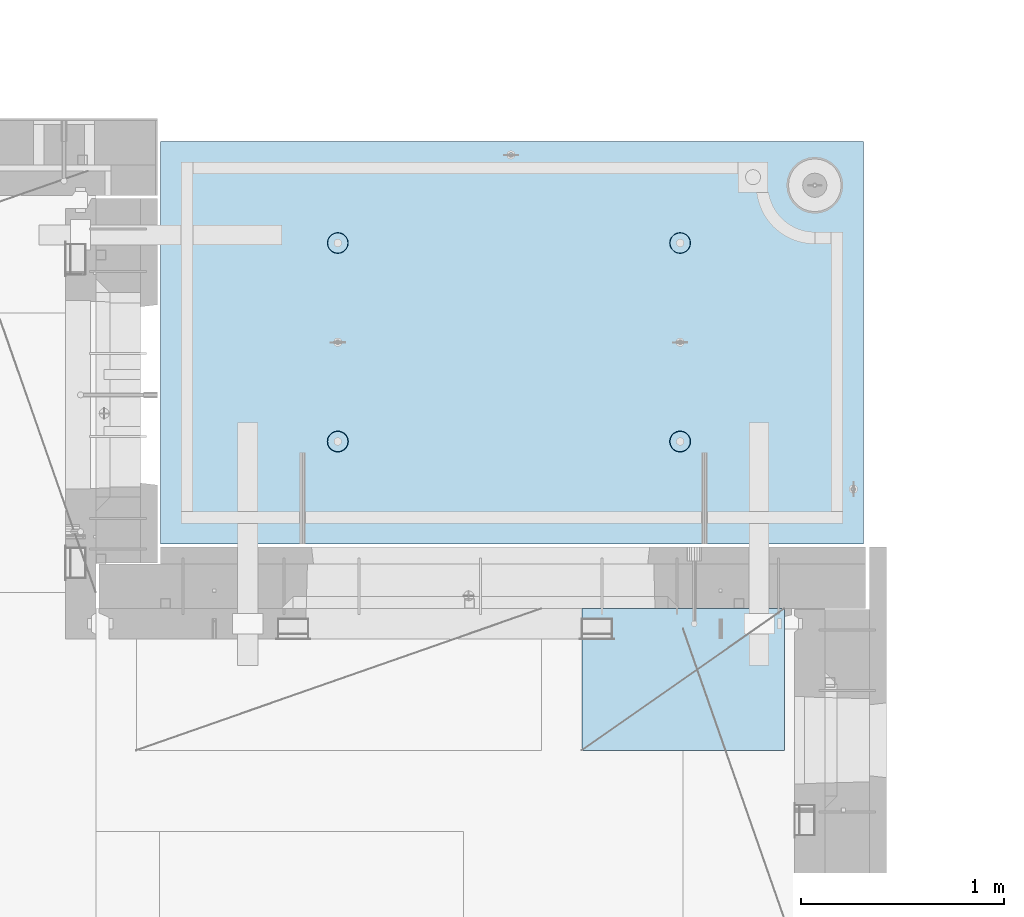
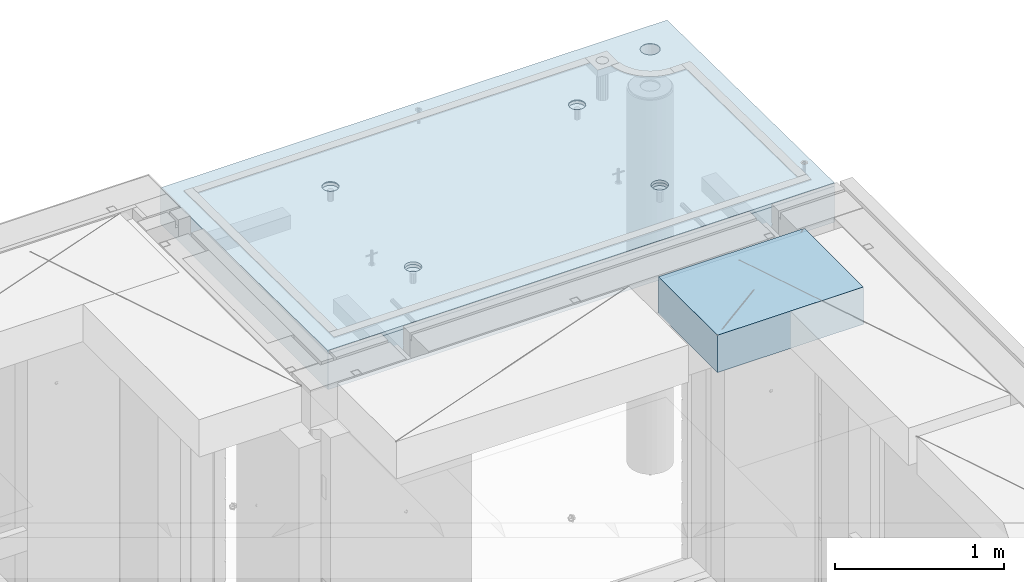
# One storey, part 191 of 325: 2 slabs, 1 plate, 2 elements without a shape of their own.
"""IFC2X3 building model written with IfcOpenShell, lengths in millimetres."""

from ifc_helpers import new_model, si_unit, frame, origin_with_axes, place, context, subcontext, project, spatial, faceted_brep, material, type_object, element, aggregate, save


model = new_model("IFC2X3")

# Units and contexts
model_context = context("Model", 3, precision=1e-05, world=origin_with_axes())
body_context = subcontext(model_context, "Body", "Model", "MODEL_VIEW")
ifc_project = project(units=[si_unit("LENGTHUNIT", "METRE", prefix="MILLI"), si_unit("AREAUNIT", "SQUARE_METRE"), si_unit("VOLUMEUNIT", "CUBIC_METRE"), si_unit("MASSUNIT", "GRAM", prefix="KILO"), si_unit("TIMEUNIT", "SECOND"), si_unit("PLANEANGLEUNIT", "RADIAN"), si_unit("SOLIDANGLEUNIT", "STERADIAN"), si_unit("THERMODYNAMICTEMPERATUREUNIT", "DEGREE_CELSIUS"), si_unit("LUMINOUSINTENSITYUNIT", "LUMEN")], contexts=[model_context])

# Site, building, storey
site_placement = place(None, origin_with_axes())
site = spatial("IfcSite", under=ifc_project, at=site_placement, CompositionType="ELEMENT")
building_placement = place(site_placement, origin_with_axes())
building = spatial("IfcBuilding", under=site, at=building_placement, CompositionType="ELEMENT")
storey_placement = place(building_placement, origin_with_axes())
storey = spatial("IfcBuildingStorey", under=building, at=storey_placement, Name="1", CompositionType="ELEMENT", Elevation=0.0)

# Assembly, slabs
assembly_1_placement = place(storey_placement, origin_with_axes())
assembly_1 = element("IfcElementAssembly", 1, at=assembly_1_placement, inside=storey, AssemblyPlace="NOTDEFINED", PredefinedType="REINFORCEMENT_UNIT")
ifc_material_1 = material(Name="CONCRETE/C35/45")
slab_type_1 = type_object("IfcSlabType", PredefinedType="NOTDEFINED")
slab_1_placement = place(assembly_1_placement, frame((31779.9998568133, 20899.9965573523, 84717.5), z_axis=(0.0, 1.0, 0.0), x_axis=(1.0, 0.0, 0.0)))
slab_1 = element("IfcSlab", 2, at=slab_1_placement, type_object=slab_type_1, material=ifc_material_1, PredefinedType="FLOOR", context=body_context, shape_type="Brep", body=[
    faceted_brep([(3287.06232936882, 9.55874156874779, 1751.46731182328), (3287.06232936882, 12.4999999999563, 1751.46731182328), (3278.5399580536, 12.4999999999563, 1734.74121634823), (3278.5399580536, 9.3480858430994, 1734.74121634823), (3265.26605352866, 12.4999999999563, 1721.46731182328), (3265.26605352866, 9.18090851265879, 1721.46731182328), (3248.5399580536, 12.4999999999563, 1712.94494050807), (3248.5399580536, 9.07357405936637, 1712.94494050807), (3229.99893839111, 12.4999999999563, 1710.00833148578), (3229.99893839111, 9.03658912732499, 1710.00833148578), (3211.45791872861, 12.4999999999563, 1712.94494050807), (3211.45791872861, 9.07357405936637, 1712.94494050807), (3194.73182325356, 12.4999999999563, 1721.46731182328), (3194.73182325356, 9.18090851267334, 1721.46731182328), (3181.45791872861, 12.4999999999563, 1734.74121634823), (3181.45791872861, 9.3480858430994, 1734.74121634823), (3172.9355474134, 12.4999999999563, 1751.46731182328), (3172.9355474134, 9.55874156874779, 1751.46731182328), (3169.99893839111, 12.4999999999563, 1770.00833148578), (3169.99893839111, 9.79225523948844, 1770.00833148578), (3172.9355474134, 12.4999999999563, 1788.54935114827), (3172.9355474134, 10.0257689102291, 1788.54935114827), (3181.45791872861, 12.4999999999563, 1805.27544662332), (3181.45791872861, 10.236424635892, 1805.27544662332), (3194.73182325356, 12.4999999999563, 1818.54935114827), (3194.73182325356, 10.4036019663181, 1818.54935114827), (3211.45791872861, 12.4999999999563, 1827.07172246349), (3211.45791872861, 10.5109364196105, 1827.07172246349), (3229.99893839111, 12.4999999999563, 1830.00833148578), (3229.99893839111, 10.5479213516664, 1830.00833148578), (3248.5399580536, 12.4999999999563, 1827.07172246349), (3248.5399580536, 10.5109364196105, 1827.07172246349), (3265.26605352866, 12.4999999999563, 1818.54935114827), (3265.26605352866, 10.4036019663181, 1818.54935114827), (3278.5399580536, 12.4999999999563, 1805.27544662332), (3278.5399580536, 10.2364246358775, 1805.27544662332), (3287.06232936882, 12.4999999999563, 1788.54935114827), (3287.06232936882, 10.0257689102291, 1788.54935114827), (3289.99893839111, 12.4999999999563, 1770.00833148578), (3289.99893839111, 9.79225523948844, 1770.00833148578), (7.41420080885291e-08, 12.4999999999927, 0.0), (-7.41420080885291e-08, -12.5, -3.63797880709171e-12), (0.0, 12.5, 1985.00366210938), (3470.0, 12.5, 0.0), (3470.00000000004, 12.4999999999563, 1985.00366210935), (3470.0, -12.5, 0.0), (2614.71871715545, -5.93617388149141, 521.168755308547), (2613.67503600632, 12.4999999999709, 520.829642746605), (2616.18047624359, 12.4999999999709, 505.010915653602), (2617.28998057371, -6.13967274603783, 505.010915653602), (2607.28293696061, -5.7526757610467, 535.738532951145), (2606.40396524136, 12.4999999999709, 535.099922616191), (2595.7125242481, -5.60710538028798, 547.296842506817), (2595.0790070157, 12.4999999999709, 546.424880841845), (2581.14006820649, -5.51366887726181, 554.715714533479), (2580.80872714612, 12.4999999999709, 553.695951606805), (2564.99000005311, -5.48147745869937, 557.271717883286), (2564.99000005311, 12.4999999999709, 556.201391844079), (2548.83993189974, -5.51366887726181, 554.715714533479), (2549.17127296011, 12.4999999999709, 553.695951606805), (2534.26747585813, -5.60710538028798, 547.296842506817), (2534.90099309052, 12.4999999999709, 546.424880841845), (2522.69706314561, -5.75267576103215, 535.738532951145), (2523.57603486487, 12.4999999999709, 535.099922616191), (2515.26128295077, -5.93617388147686, 521.168755308547), (2516.30496409991, 12.4999999999709, 520.829642746605), (2512.69001953251, -6.13967274603783, 505.010915653602), (2513.79952386263, 12.4999999999709, 505.010915653602), (2515.23823726424, -6.34326591769059, 488.84558800119), (2516.30496409991, 12.4999999999709, 489.192188560599), (2522.65977443627, -6.52701093736687, 474.256206522903), (2523.57603486487, 12.4999999999709, 474.921908691009), (2534.2301871423, -6.67288650246337, 462.673665286093), (2534.90099309052, 12.4999999999709, 463.596950465359), (2548.81688620273, -6.76656990486663, 455.235189411429), (2549.17127296011, 12.4999999999709, 456.325879700398), (2564.99000005311, -6.79885563062271, 452.67169805654), (2564.99000005311, 12.4999999999709, 453.820439463125), (2581.16311390349, -6.76656990486663, 455.235189411429), (2580.80872714612, 12.4999999999709, 456.325879700398), (2595.74981296392, -6.67288650246337, 462.673665286093), (2595.07900701571, 12.4999999999709, 463.596950465359), (2607.32022566996, -6.52701093736687, 474.256206522903), (2606.40396524136, 12.4999999999709, 474.921908691009), (2614.74176284199, -6.34326591769059, 488.84558800119), (2613.67503600632, 12.4999999999709, 489.192188560599), (924.718717121814, -5.93617388307757, 521.168755181017), (923.675035972585, 12.4999999999854, 520.829642619046), (926.180476209858, 12.4999999999854, 505.010915526043), (927.289980540074, -6.13967274762399, 505.010915526043), (917.282936926953, -5.75267576263286, 535.738532823641), (916.403965207624, 12.4999999999854, 535.099922488633), (905.712524214421, -5.60710538187413, 547.296842379335), (905.07900698197, 12.4999999999854, 546.424880714287), (891.140068172776, -5.51366887886252, 554.715714406011), (890.808727112384, 12.4999999999854, 553.695951479247), (874.990000019381, -5.48147746030008, 557.271717755822), (874.990000019381, 12.4999999999854, 556.20139171652), (858.839931865987, -5.51366887886252, 554.715714406011), (859.171272926378, 12.4999999999854, 553.695951479247), (844.267475824341, -5.60710538187413, 547.296842379335), (844.900993056792, 12.4999999999854, 546.424880714287), (832.697063111809, -5.75267576263286, 535.738532823641), (833.576034831138, 12.4999999999854, 535.099922488633), (825.261282916948, -5.93617388307757, 521.168755181017), (826.304964066177, 12.4999999999854, 520.829642619046), (822.690019498688, -6.13967274762399, 505.010915526043), (823.799523828904, 12.4999999999854, 505.010915526043), (825.238237230413, -6.34326591927675, 488.845587873602), (826.304964066174, 12.4999999999854, 489.19218843304), (832.659774402466, -6.52701093895303, 474.25620639529), (833.576034831141, 12.4999999999854, 474.921908563454), (844.230187108518, -6.67288650404953, 462.673665158458), (844.900993056788, 12.4999999999854, 463.5969503378), (858.816886168974, -6.76656990646734, 455.23518928378), (859.171272926378, 12.4999999999854, 456.32587957284), (874.990000019381, -6.79885563222342, 452.671697928887), (874.990000019381, 12.4999999999854, 453.820439335566), (891.163113869789, -6.76656990646734, 455.23518928378), (890.808727112384, 12.4999999999854, 456.32587957284), (905.749812930244, -6.67288650404953, 462.673665158458), (905.079006981974, 12.4999999999854, 463.5969503378), (917.320225636297, -6.52701093895303, 474.25620639529), (916.403965207621, 12.4999999999854, 474.921908563454), (924.741762808349, -6.34326591927675, 488.845587873602), (923.675035972588, 12.4999999999854, 489.19218843304), (924.02016693788, 6.4034111394576, 1500.93361352766), (923.67503595199, 12.4999999999854, 1500.82147367257), (926.18047618926, 12.4999999999854, 1485.00274657956), (926.555311256641, 6.20277086795249, 1485.00274657956), (916.688838773403, 6.58433162167785, 1515.29872631776), (916.403965187026, 12.4999999999854, 1515.09175354215), (905.280958178348, 6.7278571434581, 1526.69467377167), (905.079006961372, 12.4999999999854, 1526.4167117678), (890.913204613287, 6.81998112349538, 1534.0093312807), (890.808727091786, 12.4999999999854, 1533.68778253277), (874.989999998783, 6.85172034216521, 1536.52942989253), (874.989999998783, 12.4999999999854, 1536.19322277004), (859.066795384279, 6.81998112349538, 1534.0093312807), (859.17127290578, 12.4999999999854, 1533.68778253277), (844.699041819218, 6.7278571434581, 1526.69467377167), (844.900993036194, 12.4999999999854, 1526.4167117678), (833.291161224162, 6.58433162167785, 1515.29872631776), (833.57603481054, 12.4999999999854, 1515.09175354215), (825.959833059685, 6.4034111394576, 1500.93361352766), (826.304964045576, 12.4999999999854, 1500.82147367257), (823.424688740924, 6.20277086795249, 1485.00274657956), (823.799523808306, 12.4999999999854, 1485.00274657956), (825.93711110095, 6.00203761411831, 1469.06449681953), (826.304964045576, 12.4999999999854, 1469.18401948656), (833.254396317472, 5.82087370089721, 1454.68005557312), (833.57603481054, 12.4999999999854, 1454.91373961698), (844.66227690614, 5.67704728177341, 1443.26021682579), (844.90099303619, 12.4999999999854, 1443.58878139132), (859.044073415214, 5.58467987058975, 1435.9262308483), (859.17127290578, 12.4999999999854, 1436.31771062636), (874.989999998783, 5.55284766948898, 1433.39874941703), (874.989999998783, 12.4999999999854, 1433.81227038909), (890.935926582351, 5.58467987058975, 1435.9262308483), (890.808727091786, 12.4999999999854, 1436.31771062636), (905.317723091426, 5.67704728177341, 1443.26021682579), (905.079006961376, 12.4999999999854, 1443.58878139132), (916.725603680094, 5.82087370089721, 1454.68005557312), (916.403965187026, 12.4999999999854, 1454.91373961698), (924.042888896616, 6.00203761411831, 1469.06449681953), (923.67503595199, 12.4999999999854, 1469.18401948656), (2564.9899999698, 12.4999999999709, 1433.81227048016), (2564.9899999698, 5.55284767062403, 1433.39874950818), (2580.93592655335, 5.5846798717248, 1435.92623093945), (2580.8087270628, 12.4999999999709, 1436.31771071744), (2549.17127287679, 12.4999999999709, 1436.31771071744), (2549.04407338624, 5.5846798717248, 1435.92623093945), (2534.9009930072, 12.4999999999709, 1443.5887814824), (2534.66227687719, 5.67704728290846, 1443.26021691693), (2523.57603478155, 12.4999999999709, 1454.91373970805), (2523.25439628854, 5.82087370203226, 1454.68005566423), (2516.30496401659, 12.4999999999709, 1469.18401957764), (2515.93711107203, 6.00203761523881, 1469.06449691063), (2513.79952377931, 12.4999999999709, 1485.00274667064), (2513.424688712, 6.20277086908754, 1485.00274667064), (2516.30496401659, 12.4999999999709, 1500.82147376364), (2515.95983303076, 6.40341114059265, 1500.93361361872), (2523.57603478155, 12.4999999999709, 1515.09175363323), (2523.29116119523, 6.5843316228129, 1515.2987264088), (2534.90099300721, 12.4999999999709, 1526.41671185888), (2534.69904179027, 6.72785714459314, 1526.69467386269), (2549.17127287679, 12.4999999999709, 1533.68778262385), (2549.06679535531, 6.81998112463043, 1534.00933137171), (2564.9899999698, 12.4999999999709, 1536.19322286112), (2564.9899999698, 6.85172034330026, 1536.52942998354), (2580.8087270628, 12.4999999999709, 1533.68778262385), (2580.91320458428, 6.81998112463043, 1534.00933137171), (2595.07900693238, 12.4999999999709, 1526.41671185888), (2595.28095814932, 6.72785714459314, 1526.69467386269), (2606.40396515804, 12.4999999999709, 1515.09175363323), (2606.68883874436, 6.5843316228129, 1515.2987264088), (2613.675035923, 12.4999999999709, 1500.82147376364), (2614.02016690883, 6.40341114059265, 1500.93361361872), (2606.72560365105, 5.82087370203226, 1454.68005566423), (2595.3177230624, 5.67704728290846, 1443.26021691693), (2616.55531122759, 6.20277086908754, 1485.00274667064), (2614.04288886756, 6.00203761523881, 1469.06449691063), (2595.07900693239, 12.4999999999709, 1443.5887814824), (2606.40396515804, 12.4999999999709, 1454.91373970805), (2613.675035923, 12.4999999999709, 1469.18401957764), (2616.18047616028, 12.4999999999709, 1485.00274667064)], [[[0, 1, 2, 3]], [[3, 2, 4, 5]], [[5, 4, 6, 7]], [[7, 6, 8, 9]], [[9, 8, 10, 11]], [[11, 10, 12, 13]], [[13, 12, 14, 15]], [[15, 14, 16, 17]], [[17, 16, 18, 19]], [[19, 18, 20, 21]], [[21, 20, 22, 23]], [[23, 22, 24, 25]], [[25, 24, 26, 27]], [[27, 26, 28, 29]], [[29, 28, 30, 31]], [[31, 30, 32, 33]], [[33, 32, 34, 35]], [[35, 34, 36, 37]], [[37, 36, 38, 39]], [[39, 38, 1, 0]], [[40, 41, 42]], [[43, 44, 45]], [[40, 43, 45, 41]], [[46, 47, 48, 49]], [[50, 51, 47, 46]], [[52, 53, 51, 50]], [[54, 55, 53, 52]], [[56, 57, 55, 54]], [[58, 59, 57, 56]], [[59, 58, 60, 61]], [[61, 60, 62, 63]], [[63, 62, 64, 65]], [[65, 64, 66, 67]], [[67, 66, 68, 69]], [[69, 68, 70, 71]], [[71, 70, 72, 73]], [[73, 72, 74, 75]], [[75, 74, 76, 77]], [[78, 79, 77, 76]], [[80, 81, 79, 78]], [[82, 83, 81, 80]], [[84, 85, 83, 82]], [[49, 48, 85, 84]], [[86, 87, 88, 89]], [[90, 91, 87, 86]], [[92, 93, 91, 90]], [[94, 95, 93, 92]], [[96, 97, 95, 94]], [[98, 99, 97, 96]], [[99, 98, 100, 101]], [[101, 100, 102, 103]], [[103, 102, 104, 105]], [[105, 104, 106, 107]], [[107, 106, 108, 109]], [[109, 108, 110, 111]], [[111, 110, 112, 113]], [[113, 112, 114, 115]], [[115, 114, 116, 117]], [[118, 119, 117, 116]], [[120, 121, 119, 118]], [[122, 123, 121, 120]], [[124, 125, 123, 122]], [[89, 88, 125, 124]], [[126, 127, 128, 129]], [[130, 131, 127, 126]], [[132, 133, 131, 130]], [[134, 135, 133, 132]], [[136, 137, 135, 134]], [[138, 139, 137, 136]], [[140, 141, 139, 138]], [[142, 143, 141, 140]], [[143, 142, 144, 145]], [[145, 144, 146, 147]], [[147, 146, 148, 149]], [[149, 148, 150, 151]], [[151, 150, 152, 153]], [[153, 152, 154, 155]], [[155, 154, 156, 157]], [[157, 156, 158, 159]], [[159, 158, 160, 161]], [[162, 163, 161, 160]], [[164, 165, 163, 162]], [[129, 128, 165, 164]], [[166, 167, 168, 169]], [[170, 171, 167, 166]], [[172, 173, 171, 170]], [[174, 175, 173, 172]], [[176, 177, 175, 174]], [[178, 179, 177, 176]], [[180, 181, 179, 178]], [[182, 183, 181, 180]], [[183, 182, 184, 185]], [[185, 184, 186, 187]], [[187, 186, 188, 189]], [[189, 188, 190, 191]], [[191, 190, 192, 193]], [[193, 192, 194, 195]], [[195, 194, 196, 197]], [[44, 42, 41, 45], [3, 5, 7, 9, 11, 13, 15, 17, 19, 21, 23, 25, 27, 29, 31, 33, 35, 37, 39, 0], [198, 199, 168, 167, 171, 173, 175, 177, 179, 181, 183, 185, 187, 189, 191, 193, 195, 197, 200, 201], [162, 160, 158, 156, 154, 152, 150, 148, 146, 144, 142, 140, 138, 136, 134, 132, 130, 126, 129, 164], [122, 120, 118, 116, 114, 112, 110, 108, 106, 104, 102, 100, 98, 96, 94, 92, 90, 86, 89, 124], [82, 80, 78, 76, 74, 72, 70, 68, 66, 64, 62, 60, 58, 56, 54, 52, 50, 46, 49, 84]], [[169, 168, 199, 202]], [[198, 203, 202, 199]], [[201, 204, 203, 198]], [[200, 205, 204, 201]], [[197, 196, 205, 200]], [[43, 40, 42, 44], [34, 32, 30, 28, 26, 24, 22, 20, 18, 16, 14, 12, 10, 8, 6, 4, 2, 1, 38, 36], [194, 192, 190, 188, 186, 184, 182, 180, 178, 176, 174, 172, 170, 166, 169, 202, 203, 204, 205, 196], [131, 133, 135, 137, 139, 141, 143, 145, 147, 149, 151, 153, 155, 157, 159, 161, 163, 165, 128, 127], [91, 93, 95, 97, 99, 101, 103, 105, 107, 109, 111, 113, 115, 117, 119, 121, 123, 125, 88, 87], [51, 53, 55, 57, 59, 61, 63, 65, 67, 69, 71, 73, 75, 77, 79, 81, 83, 85, 48, 47]]]),
])
slab_type_2 = type_object("IfcSlabType", PredefinedType="NOTDEFINED")
slab_2_placement = place(assembly_1_placement, frame((31779.9998568132, 20899.9965573523, 84575.0), z_axis=(-1.19799915409591e-06, 0.999999999999282, 0.0), x_axis=(0.999999999999282, 1.19800000174933e-06, 0.0)))
slab_2 = element("IfcSlab", 3, at=slab_2_placement, type_object=slab_type_2, material=ifc_material_1, PredefinedType="FLOOR", context=body_context, shape_type="Brep", body=[
    faceted_brep([(2959.65048069304, -130.0, 1795.81551698422), (2959.65048069304, 130.000000000015, 1795.81551698422), (2951.52269537287, 130.000000000015, 1783.6488444481), (2951.52269537287, -130.0, 1783.6488444481), (2939.35761686434, 130.000000000015, 1775.51867349706), (2939.35761686434, -130.0, 1775.51867349706), (2925.00726809365, 130.000000000015, 1772.66274895821), (2925.00726809365, -130.0, 1772.66274895821), (2910.65635957491, 130.000000000015, 1775.51585945357), (2910.65635957491, -130.0, 1775.51585945357), (2898.48968703879, 130.000000000015, 1783.64364477374), (2898.48968703879, -130.0, 1783.64364477374), (2890.35951608775, 130.000000000015, 1795.80872328227), (2890.35951608775, -130.0, 1795.80872328227), (2887.5035915489, 130.000000000015, 1810.15907205296), (2887.5035915489, -130.0, 1810.15907205296), (2890.35670204427, 130.000000000015, 1824.5099805717), (2890.35670204427, -130.0, 1824.5099805717), (2898.48448736444, 130.000000000015, 1836.67665310783), (2898.48448736444, -130.0, 1836.67665310783), (2910.64956587296, 130.000000000015, 1844.80682405887), (2910.64956587296, -130.0, 1844.80682405887), (2924.99991464366, 130.000000000015, 1847.66274859772), (2924.99991464366, -130.0, 1847.66274859772), (2939.3508231624, 130.000000000015, 1844.80963810235), (2939.3508231624, -130.0, 1844.80963810235), (2951.51749569851, 130.000000000015, 1836.68185278219), (2951.51749569851, -130.0, 1836.68185278219), (2959.64766664955, 130.000000000015, 1824.51677427365), (2959.64766664955, -130.0, 1824.51677427365), (2962.50359118841, 130.000000000015, 1810.16642550296), (2962.50359118841, -130.0, 1810.16642550296), (3470.0, -130.0, -2.20097717829049e-09), (0.0, -130.0, -3.63797880709171e-12), (0.0, 130.0, -1.81898940354586e-12), (3470.0, 130.0, -2.20097717829049e-09), (3470.00048828125, -130.0, 1985.00366210938), (3470.00048828125, 130.0, 1985.00366210938), (0.000559809086553287, -130.0, 1985.00366210938), (0.000559809086553287, 130.0, 1985.00366210938), (890.443701616427, -110.0, 1437.44815412734), (904.382128602592, -110.0, 1444.55010256952), (915.443737652884, -110.0, 1455.61166772744), (922.54574140269, -110.0, 1469.55006653296), (924.992946242415, -110.0, 1485.00091139648), (922.545802711662, -110.0, 1500.4517659704), (915.443854269477, -110.0, 1514.39019295657), (904.382289111563, -110.0, 1525.45180200686), (890.44389030604, -110.0, 1532.55380575666), (874.993045442512, -110.0, 1535.00101059639), (859.5421908686, -110.0, 1532.55386706564), (845.603763882435, -110.0, 1525.45191862345), (834.542154832139, -110.0, 1514.39035346554), (827.440151082337, -110.0, 1500.45195466001), (824.992946242612, -110.0, 1485.00110979649), (827.440089773365, -110.0, 1469.55025522257), (834.542038215546, -110.0, 1455.61182823641), (845.603603373464, -110.0, 1444.55021918611), (859.542002178987, -110.0, 1437.44821543631), (874.992847042511, -110.0, 1435.00101059658), (923.678013579975, -130.0, 1500.81964109834), (926.183422432889, -130.0, 1485.00090903458), (916.406971127264, -130.0, 1515.08993539371), (905.082035370349, -130.0, 1526.41491608806), (890.811769926597, -130.0, 1533.68601516524), (874.993047804415, -130.0, 1536.19148678686), (859.174315740653, -130.0, 1533.68607793395), (844.904021445287, -130.0, 1526.41503548124), (833.579040750941, -130.0, 1515.09009972432), (826.307941673756, -130.0, 1500.81983428057), (823.802470052138, -130.0, 1485.00111215839), (826.307878905049, -130.0, 1469.18238009463), (833.578921357763, -130.0, 1454.91208579926), (844.903857114674, -130.0, 1443.58710510491), (859.17412255843, -130.0, 1436.31600602773), (874.992844680608, -130.0, 1433.81053440611), (890.811576744374, -130.0, 1436.31594325902), (905.081871039736, -130.0, 1443.58698571173), (916.406851734086, -130.0, 1454.91192146865), (923.677950811267, -130.0, 1469.1821869124), (890.441757333232, -110.0, 457.456323075745), (904.380184319398, -110.0, 464.558271517926), (915.44179336969, -110.0, 475.619836675844), (922.543797119495, -110.0, 489.558235481371), (924.991001959221, -110.0, 505.009080344891), (922.543858428468, -110.0, 520.459934918807), (915.441909986286, -110.0, 534.398361904972), (904.380344828369, -110.0, 545.459970955264), (890.441946022846, -110.0, 552.56197470507), (874.991101159318, -110.0, 555.009179544795), (859.540246585406, -110.0, 552.562036014042), (845.60181959924, -110.0, 545.460087571857), (834.540210548948, -110.0, 534.398522413943), (827.438206799143, -110.0, 520.46012360842), (824.991001959417, -110.0, 505.009278744892), (827.43814549017, -110.0, 489.558424170984), (834.540093932352, -110.0, 475.619997184815), (845.601659090269, -110.0, 464.558388134519), (859.540057895792, -110.0, 457.456384384717), (874.99090275932, -110.0, 455.009179544992), (923.676069296784, -130.0, 520.827810046754), (926.181478149694, -130.0, 505.009077982988), (916.405026844073, -130.0, 535.098104342116), (905.080091087159, -130.0, 546.423085036466), (890.809825643402, -130.0, 553.694184113647), (874.991103521224, -130.0, 556.199655735272), (859.172371457458, -130.0, 553.694246882354), (844.902077162096, -130.0, 546.423204429644), (833.57709646775, -130.0, 535.098268672729), (826.305997390566, -130.0, 520.828003228977), (823.800525768944, -130.0, 505.009281106795), (826.305934621854, -130.0, 489.190549043033), (833.576977074568, -130.0, 474.920254747667), (844.901912831479, -130.0, 463.595274053321), (859.172178275239, -130.0, 456.32417497614), (874.990900397414, -130.0, 453.818703354518), (890.809632461183, -130.0, 456.324112207432), (905.079926756542, -130.0, 463.595154660143), (916.404907450891, -130.0, 474.920090417054), (923.676006528072, -130.0, 489.19035586081), (2580.44175736364, -110.0, 457.452970243303), (2594.3801843498, -110.0, 464.554918685484), (2605.4417934001, -110.0, 475.616483843402), (2612.54379714991, -110.0, 489.554882648928), (2614.99100198962, -110.0, 505.005727512449), (2612.54385845887, -110.0, 520.456582086365), (2605.44191001669, -110.0, 534.39500907253), (2594.38034485878, -110.0, 545.456618122822), (2580.44194605325, -110.0, 552.558621872628), (2564.99110118972, -110.0, 555.005826712353), (2549.54024661581, -110.0, 552.5586831816), (2535.60181962965, -110.0, 545.456734739415), (2524.54021057935, -110.0, 534.395169581501), (2517.43820682954, -110.0, 520.456770775978), (2514.99100198982, -110.0, 505.00592591245), (2517.43814552058, -110.0, 489.555071338542), (2524.54009396276, -110.0, 475.616644352373), (2535.60165912067, -110.0, 464.555035302077), (2549.5400579262, -110.0, 457.453031552275), (2564.99090278973, -110.0, 455.00582671255), (2613.67606932719, -130.0, 520.824457214312), (2616.1814781801, -130.0, 505.005725150546), (2606.40502687448, -130.0, 535.094751509674), (2595.08009111756, -130.0, 546.419732204024), (2580.80982567381, -130.0, 553.690831281205), (2564.99110355163, -130.0, 556.19630290283), (2549.17237148786, -130.0, 553.690894049912), (2534.9020771925, -130.0, 546.419851597202), (2523.57709649815, -130.0, 535.094915840287), (2516.30599742097, -130.0, 520.824650396535), (2513.80052579935, -130.0, 505.005928274353), (2516.30593465226, -130.0, 489.187196210591), (2523.57697710497, -130.0, 474.916901915225), (2534.90191286189, -130.0, 463.591921220879), (2549.17217830564, -130.0, 456.320822143698), (2564.99090042782, -130.0, 453.815350522076), (2580.80963249159, -130.0, 456.32075937499), (2595.07992678695, -130.0, 463.591801827701), (2606.4049074813, -130.0, 474.916737584612), (2613.67600655848, -130.0, 489.187003028368), (2580.44370158411, -110.0, 1437.44480125841), (2594.38212857028, -110.0, 1444.5467497006), (2605.44373762057, -110.0, 1455.60831485851), (2612.54574137038, -110.0, 1469.54671366404), (2614.9929462101, -110.0, 1484.99755852756), (2612.54580267935, -110.0, 1500.44841310148), (2605.44385423717, -110.0, 1514.38684008764), (2594.38228907925, -110.0, 1525.44844913793), (2580.44389027373, -110.0, 1532.55045288774), (2564.9930454102, -110.0, 1534.99765772746), (2549.54219083629, -110.0, 1532.55051419671), (2535.60376385012, -110.0, 1525.44856575453), (2524.54215479983, -110.0, 1514.38700059661), (2517.44015105002, -110.0, 1500.44860179109), (2514.99294621029, -110.0, 1484.99775692756), (2517.44008974105, -110.0, 1469.54690235365), (2524.54203818323, -110.0, 1455.60847536748), (2535.60360334115, -110.0, 1444.54686631719), (2549.54200214667, -110.0, 1437.44486256739), (2564.9928470102, -110.0, 1434.99765772766), (2613.67801354766, -130.0, 1500.81628822942), (2616.18342240057, -130.0, 1484.99755616566), (2606.40697109495, -130.0, 1515.08658252479), (2595.08203533804, -130.0, 1526.41156321914), (2580.81176989429, -130.0, 1533.68266229632), (2564.9930477721, -130.0, 1536.18813391794), (2549.17431570834, -130.0, 1533.68272506502), (2534.90402141297, -130.0, 1526.41168261231), (2523.57904071863, -130.0, 1515.0867468554), (2516.30794164144, -130.0, 1500.81648141164), (2513.80247001983, -130.0, 1484.99775928947), (2516.30787887274, -130.0, 1469.1790272257), (2523.57892132545, -130.0, 1454.90873293034), (2534.90385708237, -130.0, 1443.58375223599), (2549.17412252611, -130.0, 1436.31265315881), (2564.99284464829, -130.0, 1433.80718153719), (2580.81157671207, -130.0, 1436.3125903901), (2595.08187100743, -130.0, 1443.58363284281), (2606.40685170178, -130.0, 1454.90856859972), (2613.67795077896, -130.0, 1469.17883404348), (3278.54339977372, -130.0, 1734.73471172154), (3265.26946891338, -130.0, 1721.46083353204), (3248.54335652997, -130.0, 1712.93849540142), (3230.00233104128, -130.0, 1710.00192316452), (3211.46131720506, -130.0, 1712.93856897219), (3194.73523863843, -130.0, 1721.46097347196), (3181.46136044892, -130.0, 1734.73490433231), (3172.9390223183, -130.0, 1751.46101671571), (3170.0024500814, -130.0, 1770.0020422044), (3172.93909588907, -130.0, 1788.54305604063), (3181.46150038884, -130.0, 1805.26913460726), (3194.73543124919, -130.0, 1818.54301279676), (3211.46154363259, -130.0, 1827.06535092738), (3230.00256912128, -130.0, 1830.00192316428), (3248.54358295751, -130.0, 1827.06527735662), (3265.26966152415, -130.0, 1818.54287285685), (3278.54353971364, -130.0, 1805.2689419965), (3287.06587784427, -130.0, 1788.5428296131), (3290.00245008117, -130.0, 1770.0018041244), (3287.0658042735, -130.0, 1751.46079028817), (3278.54353971364, 130.0, 1805.2689419965), (3287.06587784427, 130.0, 1788.5428296131), (3265.26966152415, 130.0, 1818.54287285685), (3248.54358295751, 130.0, 1827.06527735662), (3230.00256912128, 130.0, 1830.00192316428), (3211.46154363259, 130.0, 1827.06535092738), (3194.73543124919, 130.0, 1818.54301279676), (3181.46150038884, 130.0, 1805.26913460726), (3172.93909588907, 130.0, 1788.54305604063), (3170.0024500814, 130.0, 1770.0020422044), (3172.9390223183, 130.0, 1751.46101671571), (3181.46136044892, 130.0, 1734.73490433231), (3194.73523863843, 130.0, 1721.46097347196), (3211.46131720506, 130.0, 1712.93856897219), (3230.00233104128, 130.0, 1710.00192316452), (3248.54335652997, 130.0, 1712.93849540142), (3265.26946891338, 130.0, 1721.46083353204), (3278.54339977372, 130.0, 1734.73471172154), (3287.0658042735, 130.0, 1751.46079028817), (3290.00245008117, 130.0, 1770.0018041244)], [[[0, 1, 2, 3]], [[3, 2, 4, 5]], [[5, 4, 6, 7]], [[7, 6, 8, 9]], [[9, 8, 10, 11]], [[11, 10, 12, 13]], [[13, 12, 14, 15]], [[15, 14, 16, 17]], [[17, 16, 18, 19]], [[19, 18, 20, 21]], [[21, 20, 22, 23]], [[23, 22, 24, 25]], [[25, 24, 26, 27]], [[27, 26, 28, 29]], [[29, 28, 30, 31]], [[31, 30, 1, 0]], [[32, 33, 34, 35]], [[36, 32, 35, 37]], [[38, 36, 37, 39]], [[33, 38, 39, 34]], [[40, 41, 42, 43, 44, 45, 46, 47, 48, 49, 50, 51, 52, 53, 54, 55, 56, 57, 58, 59]], [[60, 45, 44, 61]], [[62, 46, 45, 60]], [[63, 47, 46, 62]], [[64, 48, 47, 63]], [[65, 49, 48, 64]], [[66, 50, 49, 65]], [[67, 51, 50, 66]], [[68, 52, 51, 67]], [[69, 53, 52, 68]], [[70, 54, 53, 69]], [[71, 55, 54, 70]], [[72, 56, 55, 71]], [[73, 57, 56, 72]], [[74, 58, 57, 73]], [[75, 59, 58, 74]], [[76, 40, 59, 75]], [[77, 41, 40, 76]], [[78, 42, 41, 77]], [[79, 43, 42, 78]], [[61, 44, 43, 79]], [[80, 81, 82, 83, 84, 85, 86, 87, 88, 89, 90, 91, 92, 93, 94, 95, 96, 97, 98, 99]], [[100, 85, 84, 101]], [[102, 86, 85, 100]], [[103, 87, 86, 102]], [[104, 88, 87, 103]], [[105, 89, 88, 104]], [[106, 90, 89, 105]], [[107, 91, 90, 106]], [[108, 92, 91, 107]], [[109, 93, 92, 108]], [[110, 94, 93, 109]], [[111, 95, 94, 110]], [[112, 96, 95, 111]], [[113, 97, 96, 112]], [[114, 98, 97, 113]], [[115, 99, 98, 114]], [[116, 80, 99, 115]], [[117, 81, 80, 116]], [[118, 82, 81, 117]], [[119, 83, 82, 118]], [[101, 84, 83, 119]], [[120, 121, 122, 123, 124, 125, 126, 127, 128, 129, 130, 131, 132, 133, 134, 135, 136, 137, 138, 139]], [[140, 125, 124, 141]], [[142, 126, 125, 140]], [[143, 127, 126, 142]], [[144, 128, 127, 143]], [[145, 129, 128, 144]], [[146, 130, 129, 145]], [[147, 131, 130, 146]], [[148, 132, 131, 147]], [[149, 133, 132, 148]], [[150, 134, 133, 149]], [[151, 135, 134, 150]], [[152, 136, 135, 151]], [[153, 137, 136, 152]], [[154, 138, 137, 153]], [[155, 139, 138, 154]], [[156, 120, 139, 155]], [[157, 121, 120, 156]], [[158, 122, 121, 157]], [[159, 123, 122, 158]], [[141, 124, 123, 159]], [[160, 161, 162, 163, 164, 165, 166, 167, 168, 169, 170, 171, 172, 173, 174, 175, 176, 177, 178, 179]], [[180, 165, 164, 181]], [[182, 166, 165, 180]], [[183, 167, 166, 182]], [[184, 168, 167, 183]], [[185, 169, 168, 184]], [[186, 170, 169, 185]], [[187, 171, 170, 186]], [[188, 172, 171, 187]], [[189, 173, 172, 188]], [[190, 174, 173, 189]], [[191, 175, 174, 190]], [[192, 176, 175, 191]], [[193, 177, 176, 192]], [[194, 178, 177, 193]], [[195, 179, 178, 194]], [[196, 160, 179, 195]], [[197, 161, 160, 196]], [[198, 162, 161, 197]], [[199, 163, 162, 198]], [[181, 164, 163, 199]], [[32, 36, 38, 33], [3, 5, 7, 9, 11, 13, 15, 17, 19, 21, 23, 25, 27, 29, 31, 0], [198, 197, 196, 195, 194, 193, 192, 191, 190, 189, 188, 187, 186, 185, 184, 183, 182, 180, 181, 199], [158, 157, 156, 155, 154, 153, 152, 151, 150, 149, 148, 147, 146, 145, 144, 143, 142, 140, 141, 159], [118, 117, 116, 115, 114, 113, 112, 111, 110, 109, 108, 107, 106, 105, 104, 103, 102, 100, 101, 119], [78, 77, 76, 75, 74, 73, 72, 71, 70, 69, 68, 67, 66, 65, 64, 63, 62, 60, 61, 79], [200, 201, 202, 203, 204, 205, 206, 207, 208, 209, 210, 211, 212, 213, 214, 215, 216, 217, 218, 219]], [[216, 220, 221, 217]], [[215, 222, 220, 216]], [[214, 223, 222, 215]], [[213, 224, 223, 214]], [[212, 225, 224, 213]], [[211, 226, 225, 212]], [[210, 227, 226, 211]], [[209, 228, 227, 210]], [[208, 229, 228, 209]], [[207, 230, 229, 208]], [[206, 231, 230, 207]], [[205, 232, 231, 206]], [[204, 233, 232, 205]], [[203, 234, 233, 204]], [[202, 235, 234, 203]], [[201, 236, 235, 202]], [[200, 237, 236, 201]], [[219, 238, 237, 200]], [[218, 239, 238, 219]], [[217, 221, 239, 218]], [[37, 35, 34, 39], [26, 24, 22, 20, 18, 16, 14, 12, 10, 8, 6, 4, 2, 1, 30, 28], [220, 222, 223, 224, 225, 226, 227, 228, 229, 230, 231, 232, 233, 234, 235, 236, 237, 238, 239, 221]]]),
])
aggregate(assembly_1, [slab_1, slab_2])

# Assembly, plate
assembly_2_placement = place(storey_placement, origin_with_axes())
assembly_2 = element("IfcElementAssembly", 4, at=assembly_2_placement, inside=storey, Name="Steel Assembly", AssemblyPlace="NOTDEFINED", PredefinedType="NOTDEFINED")
ifc_material_2 = material()
plate_type = type_object("IfcPlateType", PredefinedType="NOTDEFINED")
plate_placement = place(assembly_2_placement, frame((34860.0, 20580.0000000707, 84595.3), z_axis=(0.0, -1.0, 0.0), x_axis=(-1.0, 3.00000001838171e-08, 0.0)))
plate = element("IfcPlate", 5, at=plate_placement, type_object=plate_type, material=ifc_material_2, Name="RE1_1/2", context=body_context, shape_type="Brep", body=[
    faceted_brep([(1.81898940354586e-12, -135.0, 1.81898940354586e-12), (0.0, -135.0, 699.999999999996), (0.0, 135.0, 699.999999999996), (1.81898940354586e-12, 135.0, 1.81898940354586e-12), (999.99951171875, -135.0, 700.0), (999.99951171875, 135.0, 700.0), (1000.0, -135.0, 0.0), (1000.0, 135.0, 0.0)], [[[0, 1, 2, 3]], [[1, 4, 5, 2]], [[4, 6, 7, 5]], [[6, 0, 3, 7]], [[5, 7, 3, 2]], [[6, 4, 1, 0]]]),
])
aggregate(assembly_2, [plate])

save(model, "model.ifc")
